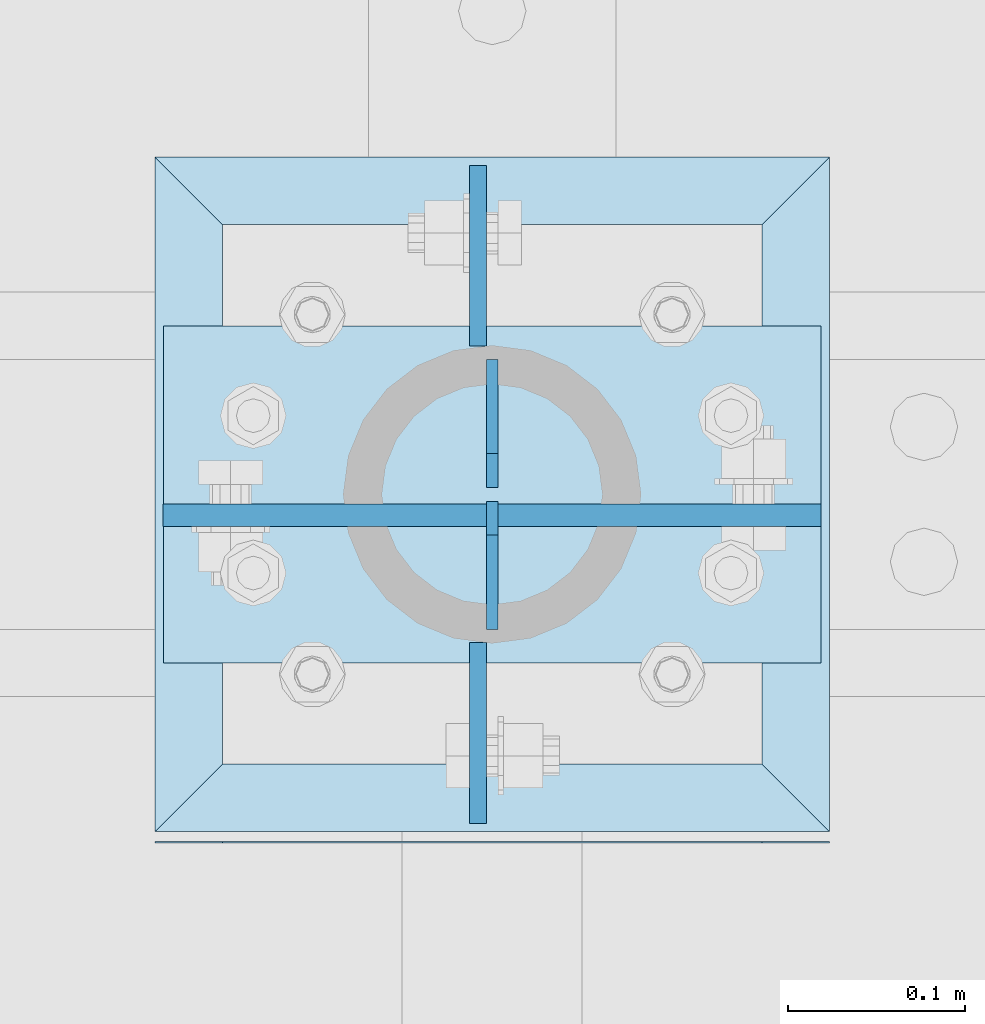
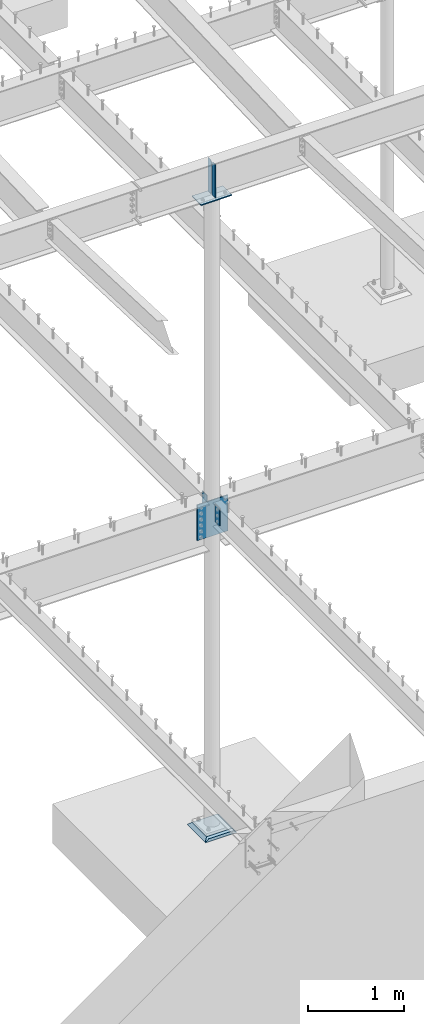
# One storey, part 848 of 975: 7 plates.
"""IFC2X3 building model written with IfcOpenShell, lengths in millimetres."""

from ifc_helpers import new_model, si_unit, frame, origin_with_axes, place, context, subcontext, project, spatial, faceted_brep, material, type_object, element, save


model = new_model("IFC2X3")

# Units and contexts
model_context = context("Model", 3, precision=1e-05, world=origin_with_axes())
body_context = subcontext(model_context, "Body", "Model", "MODEL_VIEW")
ifc_project = project(units=[si_unit("LENGTHUNIT", "METRE", prefix="MILLI"), si_unit("AREAUNIT", "SQUARE_METRE"), si_unit("VOLUMEUNIT", "CUBIC_METRE"), si_unit("MASSUNIT", "GRAM", prefix="KILO"), si_unit("TIMEUNIT", "SECOND"), si_unit("PLANEANGLEUNIT", "RADIAN"), si_unit("SOLIDANGLEUNIT", "STERADIAN"), si_unit("THERMODYNAMICTEMPERATUREUNIT", "DEGREE_CELSIUS"), si_unit("LUMINOUSINTENSITYUNIT", "LUMEN")], contexts=[model_context])

# Site, building, storey
site_placement = place(None, origin_with_axes())
site = spatial("IfcSite", under=ifc_project, at=site_placement, CompositionType="ELEMENT")
building_placement = place(site_placement, origin_with_axes())
building = spatial("IfcBuilding", under=site, at=building_placement, Name="Undefined", CompositionType="ELEMENT")
storey_placement = place(building_placement, origin_with_axes())
storey = spatial("IfcBuildingStorey", under=building, at=storey_placement, Name="Undefined", CompositionType="ELEMENT", Elevation=0.0)

# Plates
ifc_material_1 = material(Name="STEEL/A36")
plate_type_1 = type_object("IfcPlateType", PredefinedType="NOTDEFINED")
plate_1_placement = place(storey_placement, frame((13479.4625, 5903.55800332016, 3898.9), z_axis=(0.0, 1.0, 0.0), x_axis=(0.0, 0.0, -1.0)))
element("IfcPlate", 1, at=plate_1_placement, inside=storey, type_object=plate_type_1, material=ifc_material_1, Name="PLATE", context=body_context, shape_type="Brep", body=[
    faceted_brep([(0.0, -4.76250000000073, 0.0), (0.0, -4.76250000000073, 102.017997741699), (0.0, 4.76250000000073, 102.017997741699), (0.0, 4.76250000000073, 0.0), (304.799987792969, -4.76250000000073, 102.017997741699), (304.799987792969, 4.76250000000073, 102.017997741699), (304.799987792969, -4.76249999999982, 0.0), (304.799987792969, 4.76249999999982, 0.0)], [[[0, 1, 2, 3]], [[1, 4, 5, 2]], [[4, 6, 7, 5]], [[6, 0, 3, 7]], [[5, 7, 3, 2]], [[6, 4, 1, 0]]]),
])
plate_2_placement = place(storey_placement, frame((13479.4625, 5735.99199667984, 3898.9), z_axis=(0.0, -1.0, 0.0), x_axis=(0.0, 0.0, -1.0)))
element("IfcPlate", 2, at=plate_2_placement, inside=storey, type_object=plate_type_1, material=ifc_material_1, Name="PLATE", context=body_context, shape_type="Brep", body=[
    faceted_brep([(0.0, -4.76250000000073, 0.0), (0.0, -4.76250000000073, 102.017997741699), (0.0, 4.76250000000073, 102.017997741699), (0.0, 4.76250000000073, 0.0), (228.600006103516, -4.76250000000073, 102.017997741699), (228.600006103516, 4.76250000000073, 102.017997741699), (228.599990844727, -4.76249999999982, 0.0), (228.599990844727, 4.76250000000027, -7.27595761418343e-12)], [[[0, 1, 2, 3]], [[1, 4, 5, 2]], [[4, 6, 7, 5]], [[6, 0, 3, 7]], [[5, 7, 3, 2]], [[6, 4, 1, 0]]]),
])
plate_type_2 = type_object("IfcPlateType", PredefinedType="NOTDEFINED")
for number, where, z_axis, x_axis, name in (
    (3, (13487.4, 5743.575, 8218.4875), (0.0, 0.0, -1.0), (0.0, 1.0, 0.0), "PLATE"),
    (4, (13487.4, 5895.975, 8218.4875), (0.0, 0.0, -1.0), (0.0, -1.0, 0.0), "PLATE"),
):
    element("IfcPlate", number, at=place(storey_placement, frame(where, z_axis=z_axis, x_axis=x_axis)), inside=storey, type_object=plate_type_2, material=ifc_material_1, Name=name, context=body_context, shape_type="Brep", body=[
        faceted_brep([(0.0, -3.17499999999927, 0.0), (0.0, -3.17499999999927, 428.625), (0.0, 3.17499999999927, 428.625), (0.0, 3.17499999999927, 0.0), (53.1812477111816, -3.17499999999927, 428.625), (53.1812477111816, 3.17499999999927, 428.625), (72.2312469482422, -3.17499999999927, 409.575000762939), (72.2312469482422, 3.17499999999927, 409.575000762939), (72.2312469482422, -3.17499999999927, 19.0499992370605), (72.2312469482422, 3.17499999999927, 19.0499992370605), (53.1812477111816, -3.17499999999927, 0.0), (53.1812477111816, 3.17499999999927, 0.0)], [[[0, 1, 2, 3]], [[1, 4, 5, 2]], [[4, 6, 7, 5]], [[6, 8, 9, 7]], [[8, 10, 11, 9]], [[10, 0, 3, 11]], [[5, 7, 9, 11, 3, 2]], [[10, 8, 6, 4, 1, 0]]]),
    ])
plate_type_3 = type_object("IfcPlateType", PredefinedType="NOTDEFINED")
plate_3_placement = place(storey_placement, frame((13673.1375, 5915.025, 7772.4), z_axis=(-0.999999999999998, 6.90000001668524e-08, 0.0), x_axis=(0.0, -1.0, 0.0)))
element("IfcPlate", 5, at=plate_3_placement, inside=storey, type_object=plate_type_3, material=ifc_material_1, Name="PLATE", context=body_context, shape_type="Brep", body=[
    faceted_brep([(0.0, -6.34999999998763, -3.63797880709171e-12), (0.0, -6.34999999991669, 371.475006103814), (0.0, 6.35000000008222, 371.475006103821), (0.0, 6.34999999999491, 5.45696821063757e-12), (190.5, -6.34999999991669, 371.475006103814), (190.5, 6.35000000008222, 371.475006103821), (190.5, -6.34999999999764, -1.81898940354586e-12), (190.5, 6.34999999999945, 7.27595761418343e-12)], [[[0, 1, 2, 3]], [[1, 4, 5, 2]], [[4, 6, 7, 5]], [[6, 0, 3, 7]], [[5, 7, 3, 2]], [[6, 4, 1, 0]]]),
])
plate_type_4 = type_object("IfcPlateType", PredefinedType="NOTDEFINED")
plate_4_placement = place(storey_placement, frame((13391.2304941897, 5807.86875, 3898.9), z_axis=(0.0, 0.0, -1.0), x_axis=(1.0, 0.0, 0.0)))
element("IfcPlate", 6, at=plate_4_placement, inside=storey, type_object=plate_type_4, material=ifc_material_1, Name="PLATE", context=body_context, shape_type="Brep", body=[
    faceted_brep([(0.0, -6.34999999998763, -3.63797880709171e-12), (-89.6314926147461, -6.35000000000036, 0.0), (-89.6314926147461, 6.35000000000036, 0.0), (0.0, 6.34999999999491, 5.45696821063757e-12), (-89.6314926147461, -6.35000000000036, 457.200012207031), (-89.6314926147461, 6.35000000000036, 457.200012207031), (281.970520019531, -6.35000000000036, 457.200012207031), (281.970520019531, 6.35000000000036, 457.200012207031), (281.970520019531, -6.35000000000036, 0.0), (281.970520019531, 6.35000000000036, 0.0)], [[[0, 1, 2, 3]], [[1, 4, 5, 2]], [[4, 6, 7, 5]], [[6, 8, 9, 7]], [[8, 0, 3, 9]], [[5, 7, 9, 3, 2]], [[8, 6, 4, 1, 0]]]),
])
ifc_material_2 = material(Name="CONCRETE/GROUT")
plate_type_5 = type_object("IfcPlateType", PredefinedType="NOTDEFINED")
plate_5_placement = place(storey_placement, frame((13677.9, 5622.925, -285.749999999998), z_axis=(-0.999999999999998, 6.90000001668524e-08, 0.0), x_axis=(0.0, 1.0, 0.0)))
element("IfcPlate", 7, at=plate_5_placement, inside=storey, type_object=plate_type_5, material=ifc_material_2, Name="GROUT", context=body_context, shape_type="Brep", body=[
    faceted_brep([(44.4500000000035, -19.05, 342.900000000136), (6.35000000010496, 19.05, 381.0), (6.35000226069315, 19.0499999997364, -1.02318153949454e-11), (44.4500000000035, -19.05, 38.099999999893), (349.249999999983, -19.05, 38.099999999893), (387.350006103516, 19.05, 0.0), (387.350006103516, 19.05, 381.0), (349.249999999983, -19.05, 342.900000000136), (0.693145750610711, 19.05, 381.0), (0.693145750610711, -19.05, 342.900000000136), (0.693145750610711, -19.05, 38.099999999893), (0.693145750610711, 19.05, 0.0), (2.63382389675826e-07, 19.0500000000138, 0.0), (0.0, -19.05, 38.099999999893), (0.0, -19.05, 342.900000000136), (0.0, 19.05, 381.0)], [[[0, 1, 2, 3]], [[4, 5, 6, 7]], [[4, 7, 0, 3]], [[5, 4, 3, 2]], [[6, 5, 2, 1]], [[7, 6, 1, 0]], [[8, 9, 10, 11]], [[12, 13, 14, 15]], [[12, 15, 8, 11]], [[13, 12, 11, 10]], [[14, 13, 10, 9]], [[15, 14, 9, 8]]]),
])

save(model, "model.ifc")
